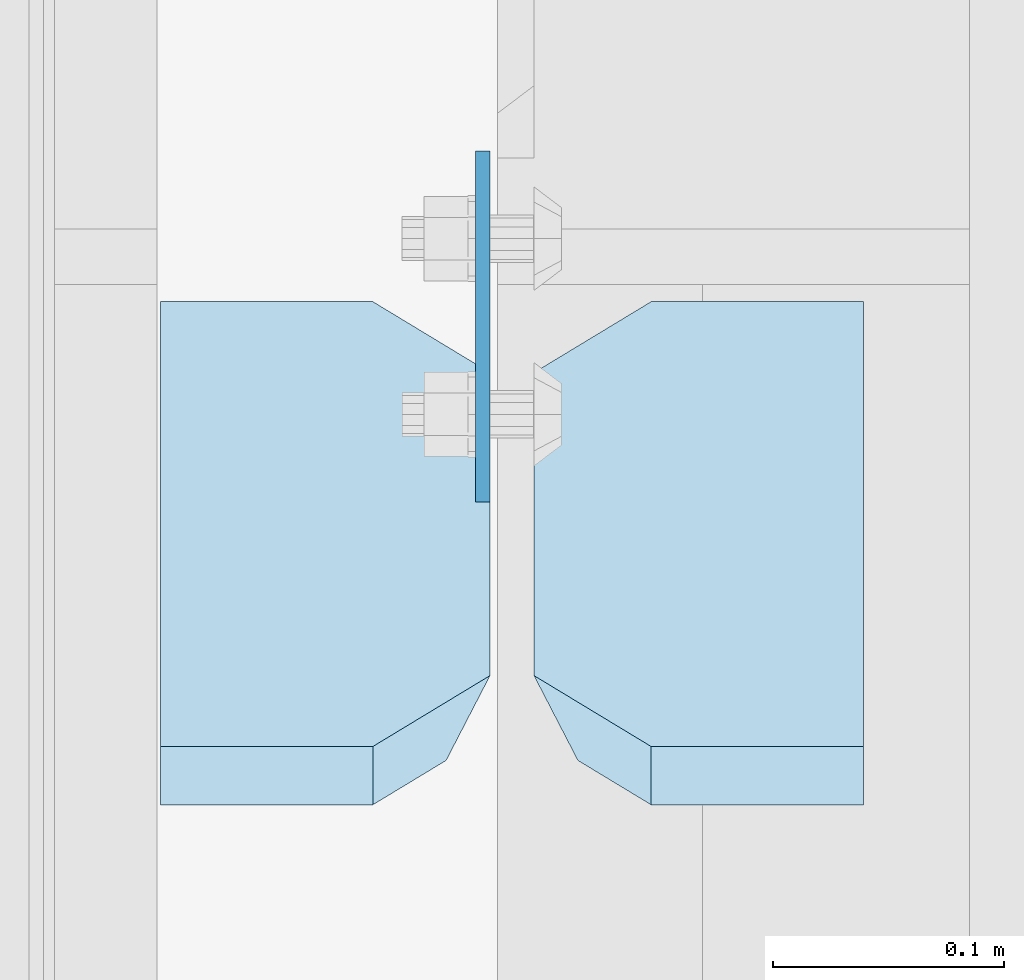
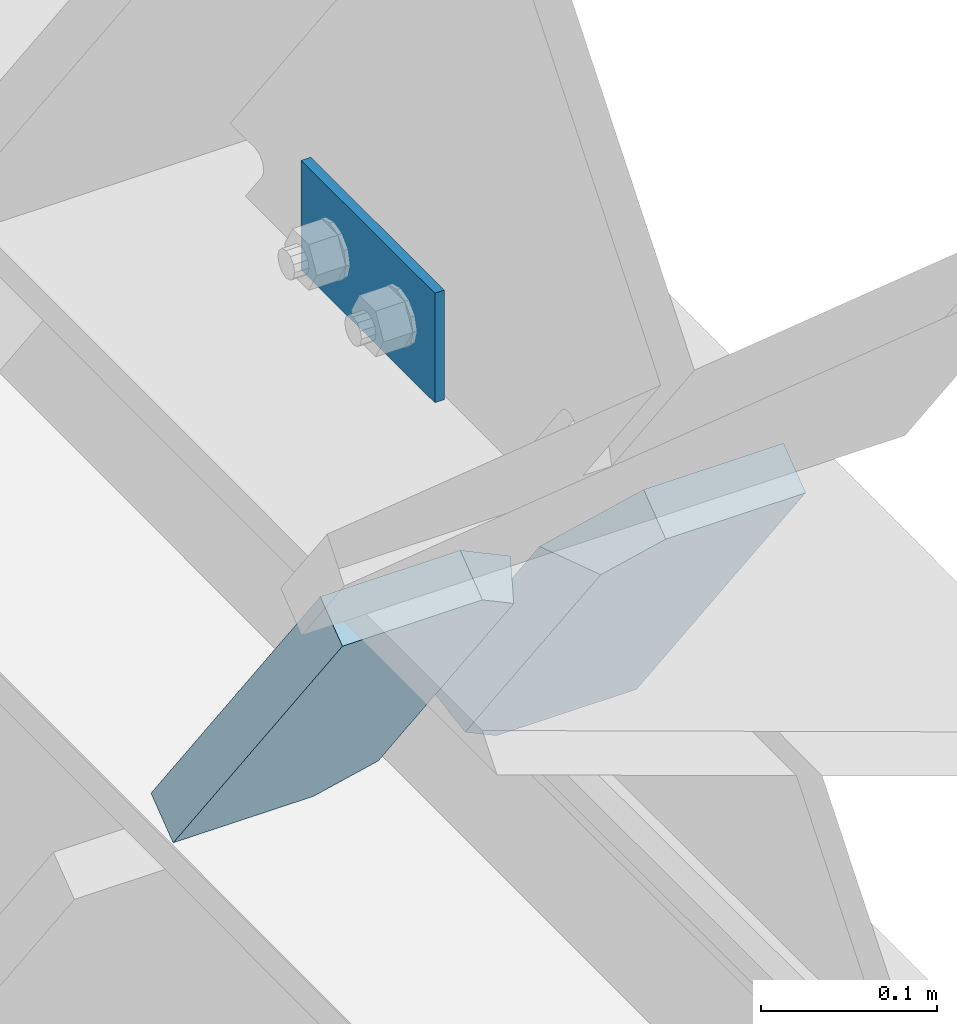
# One storey, part 3585 of 3843: 3 plates, 1 element without a shape of its own.
"""IFC2X3 building model written with IfcOpenShell, lengths in millimetres."""

from ifc_helpers import new_model, si_unit, frame, origin_with_axes, place, context, subcontext, project, spatial, faceted_brep, material, type_object, element, aggregate, save


model = new_model("IFC2X3")

# Units and contexts
model_context = context("Model", 3, precision=1e-05, world=origin_with_axes())
body_context = subcontext(model_context, "Body", "Model", "MODEL_VIEW")
ifc_project = project(units=[si_unit("LENGTHUNIT", "METRE", prefix="MILLI"), si_unit("AREAUNIT", "SQUARE_METRE"), si_unit("VOLUMEUNIT", "CUBIC_METRE"), si_unit("MASSUNIT", "GRAM", prefix="KILO"), si_unit("TIMEUNIT", "SECOND"), si_unit("PLANEANGLEUNIT", "RADIAN"), si_unit("SOLIDANGLEUNIT", "STERADIAN"), si_unit("THERMODYNAMICTEMPERATUREUNIT", "DEGREE_CELSIUS"), si_unit("LUMINOUSINTENSITYUNIT", "LUMEN")], contexts=[model_context])

# Site, building, storey
site_placement = place(None, origin_with_axes())
site = spatial("IfcSite", under=ifc_project, at=site_placement, CompositionType="ELEMENT")
building_placement = place(site_placement, origin_with_axes())
building = spatial("IfcBuilding", under=site, at=building_placement, Name="Undefined", CompositionType="ELEMENT")
storey_placement = place(building_placement, origin_with_axes())
storey = spatial("IfcBuildingStorey", under=building, at=storey_placement, Name="Undefined", CompositionType="ELEMENT", Elevation=0.0)

# Assembly, plates
assembly_placement = place(storey_placement, origin_with_axes())
assembly = element("IfcElementAssembly", 1, at=assembly_placement, inside=storey, Name="BEAM", AssemblyPlace="NOTDEFINED", PredefinedType="RIGID_FRAME")
ifc_material = material(Name="STEEL/A572-50")
plate_type_1 = type_object("IfcPlateType", PredefinedType="NOTDEFINED")
plate_1_placement = place(assembly_placement, frame((85636.1, 31550.2594780813, 42494.9451432313), z_axis=(0.0, 1.0, 0.0), x_axis=(0.0, 0.0, -1.0)))
plate_1 = element("IfcPlate", 2, at=plate_1_placement, type_object=plate_type_1, material=ifc_material, Name="PLATE", context=body_context, shape_type="Brep", body=[
    faceted_brep([(0.0, -3.17499999999927, 0.0), (1.52795109897852e-10, -3.17500000000291, 152.400000000009), (1.52795109897852e-10, 3.17500000000291, 152.400000000009), (0.0, 3.17499999999927, 0.0), (76.2000000001572, -3.17500000000291, 152.399999999921), (76.2000000001572, 3.17500000000291, 152.399999999921), (76.1999999999971, -3.17499999999927, 0.0), (76.1999999999971, 3.17499999999927, 0.0)], [[[0, 1, 2, 3]], [[1, 4, 5, 2]], [[4, 6, 7, 5]], [[6, 0, 3, 7]], [[5, 7, 3, 2]], [[6, 4, 1, 0]]]),
])
plate_type_2 = type_object("IfcPlateType", PredefinedType="NOTDEFINED")
plate_2_placement = place(assembly_placement, frame((85658.3245000839, 31624.579609891, 42132.6884975773), z_axis=(-6.23671486391687e-06, -0.605220452123432, 0.79605791516234), x_axis=(0.999999999946251, -1.03680000105758e-05, -4.80000172597793e-08)))
plate_2 = element("IfcPlate", 3, at=plate_2_placement, type_object=plate_type_2, material=ifc_material, Name="PLATE", context=body_context, shape_type="Brep", body=[
    faceted_brep([(-2.459273673594e-09, 15.8749999997126, 50.7999992372061), (19.0499999984895, -15.8750000001273, 31.7499992371449), (19.0499999829335, -15.8750000010623, 286.947799403366), (-1.59780029207468e-08, 15.8749999988286, 267.897799403378), (50.7999992180994, -15.8750000012005, 318.697798640555), (50.7999992180703, 15.8749999985957, 318.697798640627), (142.875502948882, -15.8750000012369, 318.697798640525), (142.875502948853, 15.8749999985594, 318.697798640613), (142.875502967872, -15.8749999999636, -7.27595761418343e-11), (142.875502967843, 15.8749999998472, 1.45519152283669e-11), (50.7999992370605, -15.8750000000182, 4.36557456851006e-11), (50.799999237046, 15.8749999998727, 4.36557456851006e-11)], [[[0, 1, 2, 3]], [[4, 5, 3, 2]], [[4, 6, 7, 5]], [[6, 8, 9, 7]], [[8, 10, 11, 9]], [[11, 10, 1, 0]], [[5, 7, 9, 11, 0, 3]], [[10, 8, 6, 4, 2, 1]]]),
])
plate_3_placement = place(assembly_placement, frame((85639.275, 31624.579609891, 42132.6884975773), z_axis=(6.23671487846879e-06, -0.605220452123432, 0.79605791516234), x_axis=(-0.999999999946251, -1.03680000036491e-05, -4.79999815093066e-08)))
plate_3 = element("IfcPlate", 4, at=plate_3_placement, type_object=plate_type_2, material=ifc_material, Name="PLATE", context=body_context, shape_type="Brep", body=[
    faceted_brep([(-1.60071067512035e-08, -15.8749999988358, 267.897799408951), (19.0499999829044, 15.8750000010623, 286.947799408939), (19.0499999985041, 15.8750000001419, 31.7499992371595), (-2.44472175836563e-09, -15.8749999997053, 50.7999992372061), (50.7999992180994, -15.8750000012005, 318.697798640555), (50.7999992180703, 15.8749999985957, 318.697798640627), (142.875003032721, -15.8749999985594, 318.697798646157), (142.87500303275, 15.8750000012369, 318.69779864607), (142.87499542236, -15.8750000000291, 1.81898940354586e-11), (142.87499542236, 15.8750000000218, -2.5465851649642e-11), (50.7999992370605, -15.8750000000182, 4.36557456851006e-11), (50.799999237046, 15.8749999998727, 4.36557456851006e-11)], [[[0, 1, 2, 3]], [[4, 5, 1, 0]], [[4, 6, 7, 5]], [[6, 8, 9, 7]], [[8, 10, 11, 9]], [[11, 10, 3, 2]], [[5, 7, 9, 11, 2, 1]], [[10, 8, 6, 4, 0, 3]]]),
])
aggregate(assembly, [plate_1, plate_2, plate_3])

save(model, "model.ifc")
